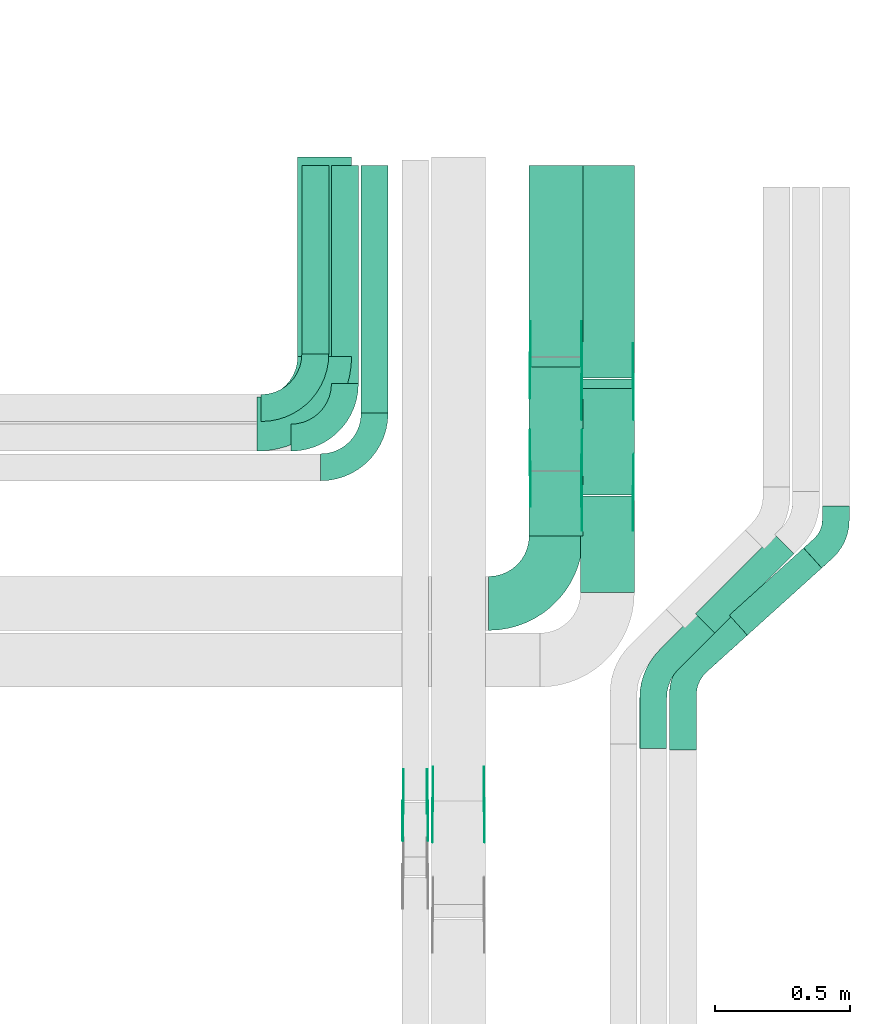
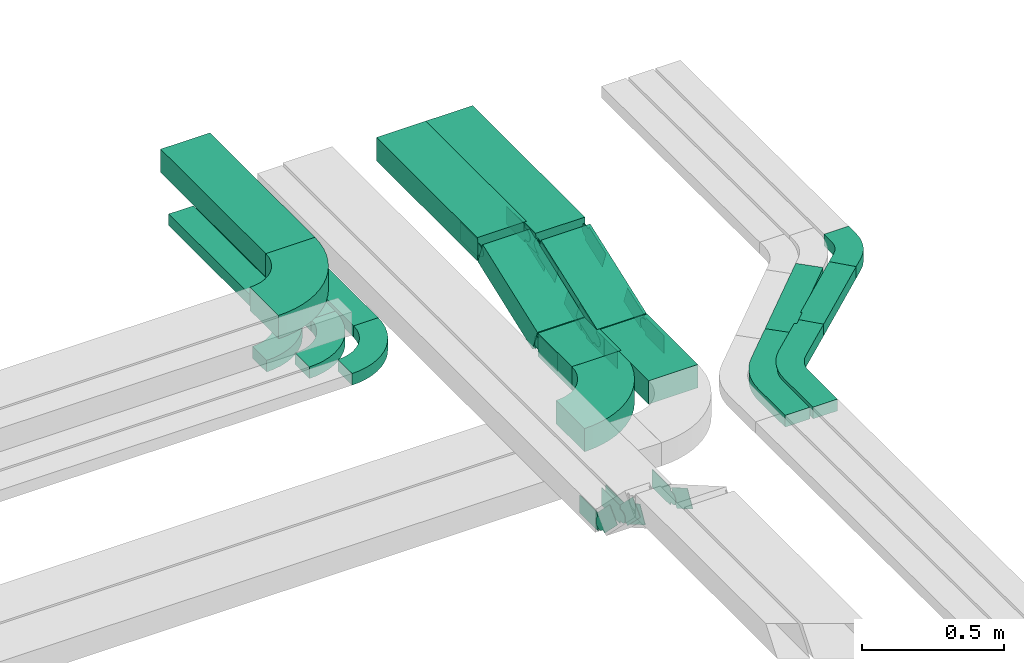
# One storey, part 22 of 25: 32 flow fittings, 12 flow segments.
"""IFC2X3 building model written with IfcOpenShell, lengths in millimetres."""

from ifc_helpers import new_model, entity, si_unit, converted_unit, derived_unit, direction, frame, frame_2d, origin, place, context, subcontext, project, spatial, polyline, circle_curve, parameter, trimmed, segment, composite_curve, rectangle, outline, extrude, source, transform, mapped, material, type_object, type_shapes, element, save


model = new_model("IFC2X3")

# Units and contexts
model_context = context("Model", 3, precision=0.01, world=origin(), true_north=direction((6.12303176911189e-17, 1.0)))
body_context = subcontext(model_context, "Body", "Model", "MODEL_VIEW")
ifc_project = project(units=[si_unit("LENGTHUNIT", "METRE", prefix="MILLI"), si_unit("AREAUNIT", "SQUARE_METRE"), si_unit("VOLUMEUNIT", "CUBIC_METRE"), converted_unit("PLANEANGLEUNIT", "DEGREE", entity("IfcRatioMeasure", 0.0174532925199433), si_unit("PLANEANGLEUNIT", "RADIAN"), dimensions=[0, 0, 0, 0, 0, 0, 0]), si_unit("MASSUNIT", "GRAM", prefix="KILO"), derived_unit("MASSDENSITYUNIT", [(si_unit("MASSUNIT", "GRAM", prefix="KILO"), 1), (si_unit("LENGTHUNIT", "METRE"), -3)]), derived_unit("MOMENTOFINERTIAUNIT", [(si_unit("LENGTHUNIT", "METRE"), 4)]), si_unit("TIMEUNIT", "SECOND"), si_unit("FREQUENCYUNIT", "HERTZ"), si_unit("THERMODYNAMICTEMPERATUREUNIT", "DEGREE_CELSIUS"), derived_unit("THERMALTRANSMITTANCEUNIT", [(si_unit("MASSUNIT", "GRAM", prefix="KILO"), 1), (si_unit("THERMODYNAMICTEMPERATUREUNIT", "KELVIN"), -1), (si_unit("TIMEUNIT", "SECOND"), -3)]), derived_unit("VOLUMETRICFLOWRATEUNIT", [(si_unit("LENGTHUNIT", "METRE"), 3), (si_unit("TIMEUNIT", "SECOND"), -1)]), derived_unit("MASSFLOWRATEUNIT", [(si_unit("MASSUNIT", "GRAM", prefix="KILO"), 1), (si_unit("TIMEUNIT", "SECOND"), -1)]), derived_unit("ROTATIONALFREQUENCYUNIT", [(si_unit("TIMEUNIT", "SECOND"), -1)]), si_unit("ELECTRICCURRENTUNIT", "AMPERE"), si_unit("ELECTRICVOLTAGEUNIT", "VOLT"), si_unit("POWERUNIT", "WATT"), si_unit("FORCEUNIT", "NEWTON", prefix="KILO"), si_unit("ILLUMINANCEUNIT", "LUX"), si_unit("LUMINOUSFLUXUNIT", "LUMEN"), si_unit("LUMINOUSINTENSITYUNIT", "CANDELA"), derived_unit("USERDEFINED", [(si_unit("MASSUNIT", "GRAM", prefix="KILO"), -1), (si_unit("LENGTHUNIT", "METRE"), -2), (si_unit("TIMEUNIT", "SECOND"), 3), (si_unit("LUMINOUSFLUXUNIT", "LUMEN"), 1)]), derived_unit("LINEARVELOCITYUNIT", [(si_unit("LENGTHUNIT", "METRE"), 1), (si_unit("TIMEUNIT", "SECOND"), -1)]), si_unit("PRESSUREUNIT", "PASCAL"), derived_unit("USERDEFINED", [(si_unit("LENGTHUNIT", "METRE"), -2), (si_unit("MASSUNIT", "GRAM", prefix="KILO"), 1), (si_unit("TIMEUNIT", "SECOND"), -2)]), derived_unit("LINEARFORCEUNIT", [(si_unit("MASSUNIT", "GRAM", prefix="KILO"), 1), (si_unit("LENGTHUNIT", "METRE"), 1), (si_unit("TIMEUNIT", "SECOND"), -2), (si_unit("LENGTHUNIT", "METRE"), -1)]), derived_unit("PLANARFORCEUNIT", [(si_unit("MASSUNIT", "GRAM", prefix="KILO"), 1), (si_unit("LENGTHUNIT", "METRE"), 1), (si_unit("TIMEUNIT", "SECOND"), -2), (si_unit("LENGTHUNIT", "METRE"), -2)])], contexts=[model_context])

# Site, building, storey
site_placement = place(None, frame((0.0, -0.00077364408347762, 0.0)))
site = spatial("IfcSite", under=ifc_project, at=site_placement, CompositionType="ELEMENT")
building_placement = place(site_placement, origin())
building = spatial("IfcBuilding", under=site, at=building_placement, CompositionType="ELEMENT")
storey_placement = place(building_placement, frame((0.0, 0.0, 24000.0)))
storey = spatial("IfcBuildingStorey", under=building, at=storey_placement, CompositionType="ELEMENT", Elevation=24000.0)

# Flow segments
cable_carrier_segment_type = type_object("IfcCableCarrierSegmentType", PredefinedType="CABLETRAYSEGMENT")
flow_segment_1_placement = place(storey_placement, frame((67285.5276000942, 9971.0, 2972.82677247422)))
element("IfcFlowSegment", 1, at=flow_segment_1_placement, inside=storey, type_object=cable_carrier_segment_type, context=body_context, shape_type="SweptSolid", body=[
    extrude(rectangle(XDim=699.000000000004, YDim=99.9999999999946, at=frame_2d((0.0, 4.33075797445781e-12), x_axis=(1.0, 0.0))), frame((50.0, 349.500000000003, 0.0), z_axis=(0.0, 0.0, 1.0), x_axis=(0.0, 1.0, 0.0)), (0.0, 0.0, 1.0), 49.9999999999973),
])
flow_segment_2_placement = place(storey_placement, frame((67395.5276000942, 9861.0, 2972.82677247422)))
element("IfcFlowSegment", 2, at=flow_segment_2_placement, inside=storey, type_object=cable_carrier_segment_type, context=body_context, shape_type="SweptSolid", body=[
    extrude(rectangle(XDim=809.000000000002, YDim=99.9999999999946, at=frame_2d((-1.08002495835535e-12, -4.33075797445781e-12), x_axis=(1.0, 0.0))), frame((50.0, 404.500000000003, 0.0), z_axis=(0.0, 0.0, 1.0), x_axis=(0.0, 1.0, 0.0)), (0.0, 0.0, 1.0), 49.9999999999973),
])
flow_segment_3_placement = place(storey_placement, frame((67505.5276000942, 9751.0, 2972.82677247422)))
element("IfcFlowSegment", 3, at=flow_segment_3_placement, inside=storey, type_object=cable_carrier_segment_type, context=body_context, shape_type="SweptSolid", body=[
    extrude(rectangle(XDim=919.000000000008, YDim=99.9999999999946, at=frame_2d((0.0, 4.33075797445781e-12), x_axis=(1.0, 0.0))), frame((50.0, 459.500000000004, 0.0), z_axis=(0.0, 0.0, 1.0), x_axis=(0.0, 1.0, 0.0)), (0.0, 0.0, 1.0), 49.9999999999973),
])
flow_segment_4_placement = place(storey_placement, frame((67270.0810452562, 9961.0, 3187.82677247422)))
element("IfcFlowSegment", 4, at=flow_segment_4_placement, inside=storey, type_object=cable_carrier_segment_type, context=body_context, shape_type="SweptSolid", body=[
    extrude(rectangle(XDim=739.518749019633, YDim=200.000000000007, at=frame_2d((-1.08002495835535e-12, 4.33431068813661e-12), x_axis=(1.0, 0.0))), frame((100.0, 369.759374509821, 0.0), z_axis=(0.0, 0.0, 1.0), x_axis=(0.0, 1.0, 0.0)), (0.0, 0.0, 1.0), 100.000000000003),
])
flow_segment_5_placement = place(storey_placement, frame((68871.1932036025, 8927.17520446877, 2977.04166610498)))
element("IfcFlowSegment", 5, at=flow_segment_5_placement, inside=storey, type_object=cable_carrier_segment_type, context=body_context, shape_type="SweptSolid", body=[
    extrude(rectangle(XDim=371.773074672143, YDim=99.9999999999984, at=frame_2d((2.8421709430404e-12, -3.31112914864207e-12), x_axis=(1.0, 0.0))), frame((171.457278030255, 161.706673583962, 0.283024091859215), z_axis=(0.00112985461369591, 0.00102060214396783, 0.999998840899236), x_axis=(-0.742072934551903, -0.67031741854538, 0.00152256368811346)), (0.0, 0.0, 1.0), 49.9999999999997),
])
flow_segment_6_placement = place(storey_placement, frame((68746.1523369545, 8935.60453032384, 2976.93564155154)))
element("IfcFlowSegment", 6, at=flow_segment_6_placement, inside=storey, type_object=cable_carrier_segment_type, context=body_context, shape_type="SweptSolid", body=[
    extrude(rectangle(XDim=415.989494553877, YDim=100.00000000001, at=frame_2d((-3.05533376376843e-12, 3.06599190480483e-12), x_axis=(1.0, 0.0))), frame((182.429503323364, 182.429503323343, 0.441935376893935), z_axis=(0.0015024201617621, 0.00150242016176191, 0.99999774273111), x_axis=(-0.707105185056458, -0.707105185056359, 0.00212474296914661)), (0.0, 0.0, 1.0), 50.0000000000083),
])
flow_segment_7_placement = place(storey_placement, frame((68128.7045667398, 9295.9892313259, 2805.0)))
element("IfcFlowSegment", 7, at=flow_segment_7_placement, inside=storey, type_object=cable_carrier_segment_type, context=body_context, shape_type="SweptSolid", body=[
    extrude(rectangle(XDim=238.258949212567, YDim=200.000000000007, at=frame_2d((0.0, 4.33431068813661e-12), x_axis=(1.0, 0.0))), frame((100.0, 119.129474606295, 0.0), z_axis=(0.0, 0.0, 1.0), x_axis=(0.0, 1.0, 0.0)), (0.0, 0.0, 1.0), 100.000000000003),
])
flow_segment_8_placement = place(storey_placement, frame((68319.2384978797, 9085.989231326, 2805.0)))
element("IfcFlowSegment", 8, at=flow_segment_8_placement, inside=storey, type_object=cable_carrier_segment_type, context=body_context, shape_type="SweptSolid", body=[
    extrude(rectangle(XDim=358.479361109274, YDim=200.000000000007, at=frame_2d((5.40012479177676e-13, 0.0), x_axis=(1.0, 0.0))), frame((100.0, 179.239680554637, 0.0), z_axis=(0.0, 0.0, 1.0), x_axis=(0.0, 1.0, 0.0)), (0.0, 0.0, 1.0), 100.000000000003),
])
flow_segment_9_placement = place(storey_placement, frame((68128.7045667398, 9960.74105078756, 2956.03437973935)))
element("IfcFlowSegment", 9, at=flow_segment_9_placement, inside=storey, type_object=cable_carrier_segment_type, context=body_context, shape_type="SweptSolid", body=[
    extrude(rectangle(XDim=709.258949212396, YDim=200.000000000007, at=frame_2d((1.08002495835535e-12, 4.33431068813661e-12), x_axis=(1.0, 0.0))), frame((100.0, 354.629474606204, 0.0), z_axis=(0.0, 0.0, 1.0), x_axis=(0.0, 1.0, 0.0)), (0.0, 0.0, 1.0), 100.000000000003),
])
flow_segment_10_placement = place(storey_placement, frame((68319.2384978797, 9880.52063889088, 2956.03437973935)))
element("IfcFlowSegment", 10, at=flow_segment_10_placement, inside=storey, type_object=cable_carrier_segment_type, context=body_context, shape_type="SweptSolid", body=[
    extrude(rectangle(XDim=789.479361109084, YDim=200.000000000007, at=frame_2d((1.08002495835535e-12, 0.0), x_axis=(1.0, 0.0))), frame((100.0, 394.739680554543, 0.0), z_axis=(0.0, 0.0, 1.0), x_axis=(0.0, 1.0, 0.0)), (0.0, 0.0, 1.0), 100.000000000003),
])
flow_segment_11_placement = place(storey_placement, frame((68128.7045667398, 9537.58278936662, 2811.90452506089)))
element("IfcFlowSegment", 11, at=flow_segment_11_placement, inside=storey, type_object=cable_carrier_segment_type, context=body_context, shape_type="SweptSolid", body=[
    extrude(rectangle(XDim=100.000000000003, YDim=410.773733093381, at=frame_2d((0.0, 0.0), x_axis=(0.0, 1.0))), frame((0.0, 209.911826296397, 118.612664808778), z_axis=(1.0, 0.0, 0.0), x_axis=(0.0, -0.936970044567182, -0.34940969589262)), (0.0, 0.0, 1.0), 200.000000000007),
])
flow_segment_12_placement = place(storey_placement, frame((68319.2384978797, 9447.77624067955, 2811.61265250806)))
element("IfcFlowSegment", 12, at=flow_segment_12_placement, inside=storey, type_object=cable_carrier_segment_type, context=body_context, shape_type="SweptSolid", body=[
    extrude(rectangle(XDim=100.000000000004, YDim=420.598079588431, at=frame_2d((-5.11590769747272e-13, 1.88293824976427e-13), x_axis=(0.0, 1.0))), frame((0.0, 214.718374983531, 118.904537361611), z_axis=(1.0, 0.0, 0.0), x_axis=(0.0, -0.939705127606637, -0.341985779163101)), (0.0, 0.0, 1.0), 200.000000000006),
])

# Flow fittings
ifc_material_1 = material(Name="G")
cable_carrier_fitting_type_1 = type_object("IfcCableCarrierFittingType", PredefinedType="NOTDEFINED", material=ifc_material_1)
shared_shape_1 = source(origin(), body_context, "Body", "SweptSolid", [
    extrude(outline(composite_curve([segment(trimmed(circle_curve(frame_2d((-41.4651162790697, 0.0), x_axis=(1.0, 0.0)), 25.0), [parameter(90.0000000000007)], [parameter(270.0)], True, "PARAMETER"), True, "CONTINUOUS"), segment(polyline([(-41.4651162790697, -25.0), (-29.9651162790697, -25.0)]), True, "CONTINUOUS"), segment(polyline([(-29.9651162790697, -25.0), (-28.1046511627907, -38.5)]), True, "CONTINUOUS"), segment(polyline([(-28.1046511627907, -38.5), (99.5348837209303, -38.5)]), True, "CONTINUOUS"), segment(polyline([(99.5348837209303, -38.5), (99.5348837209303, 38.5)]), True, "CONTINUOUS"), segment(polyline([(99.5348837209303, 38.5), (-28.1046511627907, 38.5)]), True, "CONTINUOUS"), segment(polyline([(-28.1046511627907, 38.5), (-29.9651162790697, 25.0)]), True, "CONTINUOUS"), segment(polyline([(-29.9651162790697, 25.0), (-41.46511627907, 25.0)]), True, "CONTINUOUS")], self_intersect=False)), frame((41.4651162790697, 0.0, 0.0), z_axis=(0.0, 0.0, -1.0), x_axis=(1.0, 0.0, 0.0)), (0.0, 0.0, -1.0), 2.0),
])
type_shapes(cable_carrier_fitting_type_1, [shared_shape_1])
for number, where, z_axis, x_axis in (
    (13, (68324.16456675, 9950.0, 3006.03437973937), (1.0, 0.0, 0.0), (0.0, -0.93697004456712, -0.349409695892785)),
    (14, (68324.16456675, 9544.98923132608, 2855.0), (1.0, 0.0, 0.0), (0.0, 0.93697004456712, 0.349409695892785)),
    (15, (68514.6984978899, 9870.0, 3006.03437973937), (1.0, 0.0, 0.0), (0.0, -0.939705127606558, -0.34198577916332)),
    (16, (68514.6984978899, 9454.9892313262, 2855.0), (1.0, 0.0, 0.0), (0.0, 0.939705127606558, 0.34198577916332)),
    (17, (67770.8875285364, 8298.27683305022, 3005.26809891813), (-1.0, 0.0, 0.0), (0.0, -0.866025403784327, 0.500000000000193)),
    (18, (67660.8875285364, 8288.93441568023, 3005.26809891815), (-1.0, 0.0, 0.0), (0.0, -0.707106781186429, 0.707106781186666)),
):
    element("IfcFlowFitting", number, at=place(storey_placement, frame(where, z_axis=z_axis, x_axis=x_axis)), inside=storey, type_object=cable_carrier_fitting_type_1, material=ifc_material_1, context=body_context, shape_type="MappedRepresentation", body=[
        mapped(shared_shape_1, transform((0.0, 0.0, 0.0), scale=1.0)),
    ])
cable_carrier_fitting_type_2 = type_object("IfcCableCarrierFittingType", PredefinedType="NOTDEFINED", material=ifc_material_1)
shared_shape_2 = source(origin(), body_context, "Body", "SweptSolid", [
    extrude(outline(composite_curve([segment(trimmed(circle_curve(frame_2d((-41.4651162790697, 0.0), x_axis=(1.0, 0.0)), 25.0), [parameter(90.0000000000007)], [parameter(270.0)], True, "PARAMETER"), True, "CONTINUOUS"), segment(polyline([(-41.4651162790697, -25.0), (-29.9651162790697, -25.0)]), True, "CONTINUOUS"), segment(polyline([(-29.9651162790697, -25.0), (-28.1046511627907, -38.5)]), True, "CONTINUOUS"), segment(polyline([(-28.1046511627907, -38.5), (99.5348837209303, -38.5)]), True, "CONTINUOUS"), segment(polyline([(99.5348837209303, -38.5), (99.5348837209303, 38.5)]), True, "CONTINUOUS"), segment(polyline([(99.5348837209303, 38.5), (-28.1046511627907, 38.5)]), True, "CONTINUOUS"), segment(polyline([(-28.1046511627907, 38.5), (-29.9651162790697, 25.0)]), True, "CONTINUOUS"), segment(polyline([(-29.9651162790697, 25.0), (-41.46511627907, 25.0)]), True, "CONTINUOUS")], self_intersect=False)), frame((41.4651162790697, 0.0, 0.0)), (0.0, 0.0, 1.0), 2.0),
])
type_shapes(cable_carrier_fitting_type_2, [shared_shape_2])
for number, where, z_axis, x_axis in (
    (19, (68133.2445667297, 9950.0, 3006.03437973937), (-1.0, 0.0, 0.0), (0.0, -0.93697004456712, -0.349409695892785)),
    (20, (68133.2445667297, 9544.98923132608, 2855.0), (-1.0, 0.0, 0.0), (0.0, 0.93697004456712, 0.349409695892785)),
    (21, (68323.7784978696, 9870.0, 3006.03437973937), (-1.0, 0.0, 0.0), (0.0, -0.939705127606558, -0.34198577916332)),
    (22, (68323.7784978696, 9454.98923132619, 2855.0), (-1.0, 0.0, 0.0), (0.0, 0.939705127606558, 0.34198577916332)),
    (23, (67961.8075285568, 8298.27683305022, 3005.26809891813), (1.0, 0.0, 0.0), (0.0, -0.866025403784327, 0.500000000000193)),
    (24, (67751.8075285568, 8288.93441568023, 3005.26809891815), (1.0, 0.0, 0.0), (0.0, -0.707106781186429, 0.707106781186666)),
):
    element("IfcFlowFitting", number, at=place(storey_placement, frame(where, z_axis=z_axis, x_axis=x_axis)), inside=storey, type_object=cable_carrier_fitting_type_2, material=ifc_material_1, context=body_context, shape_type="MappedRepresentation", body=[
        mapped(shared_shape_2, transform((0.0, 0.0, 0.0), scale=1.0)),
    ])
cable_carrier_fitting_type_3 = type_object("IfcCableCarrierFittingType", PredefinedType="NOTDEFINED", material=ifc_material_1)
shared_shape_3 = source(origin(), body_context, "Body", "SweptSolid", [
    extrude(outline(composite_curve([segment(trimmed(circle_curve(frame_2d((-41.4651162790697, 0.0), x_axis=(1.0, 0.0)), 25.0), [parameter(90.0000000000007)], [parameter(270.0)], True, "PARAMETER"), True, "CONTINUOUS"), segment(polyline([(-41.4651162790697, -25.0), (-29.9651162790697, -25.0)]), True, "CONTINUOUS"), segment(polyline([(-29.9651162790697, -25.0), (-28.1046511627907, -38.5)]), True, "CONTINUOUS"), segment(polyline([(-28.1046511627907, -38.5), (99.5348837209303, -38.5)]), True, "CONTINUOUS"), segment(polyline([(99.5348837209303, -38.5), (99.5348837209303, 38.5)]), True, "CONTINUOUS"), segment(polyline([(99.5348837209303, 38.5), (-28.1046511627907, 38.5)]), True, "CONTINUOUS"), segment(polyline([(-28.1046511627907, 38.5), (-29.9651162790697, 25.0)]), True, "CONTINUOUS"), segment(polyline([(-29.9651162790697, 25.0), (-41.46511627907, 25.0)]), True, "CONTINUOUS")], self_intersect=False)), frame((41.4651162790697, 0.0, 0.0), z_axis=(0.0, 0.0, -1.0), x_axis=(1.0, 0.0, 0.0)), (0.0, 0.0, -1.0), 2.0),
])
type_shapes(cable_carrier_fitting_type_3, [shared_shape_3])
for number, where, z_axis, x_axis in (
    (25, (68135.2445667297, 9950.0, 3006.03437973937), (-1.0, 0.0, 0.0), (0.0, 1.0, 0.0)),
    (26, (68135.2445667297, 9544.98923132609, 2855.0), (-1.0, 0.0, 0.0), (0.0, -1.0, 0.0)),
    (27, (68325.7784978696, 9870.0, 3006.03437973937), (-1.0, 0.0, 0.0), (0.0, 1.0, 0.0)),
    (28, (68325.7784978696, 9454.98923132621, 2855.0), (-1.0, 0.0, 0.0), (0.0, -1.0, 0.0)),
    (29, (67959.8075285568, 8298.27683305021, 3005.26809891814), (1.0, 0.0, 0.0), (0.0, 1.0, 0.0)),
    (30, (67749.8075285568, 8288.93441568023, 3005.26809891815), (1.0, 0.0, 0.0), (0.0, 1.0, 0.0)),
):
    element("IfcFlowFitting", number, at=place(storey_placement, frame(where, z_axis=z_axis, x_axis=x_axis)), inside=storey, type_object=cable_carrier_fitting_type_3, material=ifc_material_1, context=body_context, shape_type="MappedRepresentation", body=[
        mapped(shared_shape_3, transform((0.0, 0.0, 0.0), scale=1.0)),
    ])
cable_carrier_fitting_type_4 = type_object("IfcCableCarrierFittingType", PredefinedType="NOTDEFINED", material=ifc_material_1)
shared_shape_4 = source(origin(), body_context, "Body", "SweptSolid", [
    extrude(outline(composite_curve([segment(trimmed(circle_curve(frame_2d((-41.4651162790697, 0.0), x_axis=(1.0, 0.0)), 25.0), [parameter(90.0000000000007)], [parameter(270.0)], True, "PARAMETER"), True, "CONTINUOUS"), segment(polyline([(-41.4651162790697, -25.0), (-29.9651162790697, -25.0)]), True, "CONTINUOUS"), segment(polyline([(-29.9651162790697, -25.0), (-28.1046511627907, -38.5)]), True, "CONTINUOUS"), segment(polyline([(-28.1046511627907, -38.5), (99.5348837209303, -38.5)]), True, "CONTINUOUS"), segment(polyline([(99.5348837209303, -38.5), (99.5348837209303, 38.5)]), True, "CONTINUOUS"), segment(polyline([(99.5348837209303, 38.5), (-28.1046511627907, 38.5)]), True, "CONTINUOUS"), segment(polyline([(-28.1046511627907, 38.5), (-29.9651162790697, 25.0)]), True, "CONTINUOUS"), segment(polyline([(-29.9651162790697, 25.0), (-41.46511627907, 25.0)]), True, "CONTINUOUS")], self_intersect=False)), frame((41.4651162790697, 0.0, 0.0)), (0.0, 0.0, 1.0), 2.0),
])
type_shapes(cable_carrier_fitting_type_4, [shared_shape_4])
for number, where, z_axis, x_axis in (
    (31, (68322.16456675, 9950.0, 3006.03437973937), (1.0, 0.0, 0.0), (0.0, 1.0, 0.0)),
    (32, (68322.16456675, 9544.98923132609, 2855.0), (1.0, 0.0, 0.0), (0.0, -1.0, 0.0)),
    (33, (68512.6984978899, 9870.0, 3006.03437973937), (1.0, 0.0, 0.0), (0.0, 1.0, 0.0)),
    (34, (68512.6984978899, 9454.98923132621, 2855.0), (1.0, 0.0, 0.0), (0.0, -1.0, 0.0)),
    (35, (67772.8875285364, 8298.27683305021, 3005.26809891814), (-1.0, 0.0, 0.0), (0.0, 1.0, 0.0)),
    (36, (67662.8875285364, 8288.93441568023, 3005.26809891816), (-1.0, 0.0, 0.0), (0.0, 1.0, 0.0)),
):
    element("IfcFlowFitting", number, at=place(storey_placement, frame(where, z_axis=z_axis, x_axis=x_axis)), inside=storey, type_object=cable_carrier_fitting_type_4, material=ifc_material_1, context=body_context, shape_type="MappedRepresentation", body=[
        mapped(shared_shape_4, transform((0.0, 0.0, 0.0), scale=1.0)),
    ])
ifc_material_2 = material()
cable_carrier_fitting_type_5 = type_object("IfcCableCarrierFittingType", Name="470_DKC_S5_Variable Angle Elbow 0-45:-", PredefinedType="NOTDEFINED", material=ifc_material_2)
shared_shape_5 = source(origin(), body_context, "Body", "SweptSolid", [
    extrude(outline(composite_curve([segment(polyline([(-125.750000000001, -225.25), (-124.749999999999, -225.25)]), True, "CONTINUOUS"), segment(trimmed(circle_curve(frame_2d((-124.75, 124.75), x_axis=(0.0, -1.0)), 350.0), [parameter(0.0)], [parameter(90.0000000000001)], True, "PARAMETER"), True, "CONTINUOUS"), segment(polyline([(225.25, 124.75), (225.25, 125.749999999999)]), True, "CONTINUOUS"), segment(polyline([(225.25, 125.749999999999), (25.25, 125.750000000001)]), True, "CONTINUOUS"), segment(polyline([(25.25, 125.750000000001), (25.25, 124.75)]), True, "CONTINUOUS"), segment(trimmed(circle_curve(frame_2d((-124.75, 124.75), x_axis=(0.0, -1.0)), 150.0), [parameter(0.0)], [parameter(90.0000000000001)], True, "PARAMETER"), False, "CONTINUOUS"), segment(polyline([(-124.749999999999, -25.2500000000003), (-125.750000000001, -25.2500000000003)]), True, "CONTINUOUS"), segment(polyline([(-125.750000000001, -25.2500000000003), (-125.750000000001, -225.25)]), True, "CONTINUOUS")], self_intersect=False)), frame((-125.249999999991, 125.249999999992, -50.0)), (0.0, 0.0, 1.0), 100.0),
])
type_shapes(cable_carrier_fitting_type_5, [shared_shape_5])
for number, where, name in (
    (37, (67370.0810452562, 9710.0, 3237.82677247422), "470_DKC_S5_Variable Angle Elbow 0-45:-"),
    (38, (68228.7045667398, 9044.98923132593, 2855.0), "470_DKC_S5_Variable Angle Elbow 0-45:-"),
):
    element("IfcFlowFitting", number, at=place(storey_placement, frame(where)), inside=storey, type_object=cable_carrier_fitting_type_5, material=ifc_material_2, Name=name, ObjectType="470_DKC_S5_Variable Angle Elbow 0-45:-", context=body_context, shape_type="MappedRepresentation", body=[
        mapped(shared_shape_5, transform((0.0, 0.0, 0.0), scale=1.0)),
    ])
cable_carrier_fitting_type_6 = type_object("IfcCableCarrierFittingType", Name="470_DKC_S5_Variable Angle Elbow 0-45:-", PredefinedType="NOTDEFINED", material=ifc_material_2)
shared_shape_6 = source(origin(), body_context, "Body", "SweptSolid", [
    extrude(outline(composite_curve([segment(polyline([(-100.750000000001, -150.25), (-99.7499999999994, -150.25)]), True, "CONTINUOUS"), segment(trimmed(circle_curve(frame_2d((-99.7499999999997, 99.7499999999995), x_axis=(0.0, -1.0)), 250.0), [parameter(0.0)], [parameter(90.0000000000001)], True, "PARAMETER"), True, "CONTINUOUS"), segment(polyline([(150.25, 99.75), (150.25, 100.749999999999)]), True, "CONTINUOUS"), segment(polyline([(150.25, 100.749999999999), (50.25, 100.75)]), True, "CONTINUOUS"), segment(polyline([(50.25, 100.75), (50.25, 99.7499999999998)]), True, "CONTINUOUS"), segment(trimmed(circle_curve(frame_2d((-99.7499999999997, 99.7499999999995), x_axis=(0.0, -1.0)), 150.0), [parameter(0.0)], [parameter(90.0000000000001)], True, "PARAMETER"), False, "CONTINUOUS"), segment(polyline([(-99.7499999999994, -50.2500000000003), (-100.750000000001, -50.2500000000003)]), True, "CONTINUOUS"), segment(polyline([(-100.750000000001, -50.2500000000003), (-100.750000000001, -150.25)]), True, "CONTINUOUS")], self_intersect=False)), frame((-100.249999999991, 100.249999999992, -25.0)), (0.0, 0.0, 1.0), 49.9999999999997),
])
type_shapes(cable_carrier_fitting_type_6, [shared_shape_6])
for number, where, name in (
    (39, (67335.5276000942, 9770.0, 2997.82677247422), "470_DKC_S5_Variable Angle Elbow 0-45:-"),
    (40, (67445.5276000942, 9660.0, 2997.82677247422), "470_DKC_S5_Variable Angle Elbow 0-45:-"),
    (41, (67555.5276000942, 9550.0, 2997.82677247422), "470_DKC_S5_Variable Angle Elbow 0-45:-"),
):
    element("IfcFlowFitting", number, at=place(storey_placement, frame(where)), inside=storey, type_object=cable_carrier_fitting_type_6, material=ifc_material_2, Name=name, ObjectType="470_DKC_S5_Variable Angle Elbow 0-45:-", context=body_context, shape_type="MappedRepresentation", body=[
        mapped(shared_shape_6, transform((0.0, 0.0, 0.0), scale=1.0)),
    ])
cable_carrier_fitting_type_7 = type_object("IfcCableCarrierFittingType", Name="470_DKC_S5_CD 90 external vertical angle:-", PredefinedType="NOTDEFINED", material=ifc_material_2)
shared_shape_7 = source(origin(), body_context, "Body", "SweptSolid", [
    extrude(outline(composite_curve([segment(polyline([(-100.840217544273, -82.9627933027741), (-47.5527344484616, -82.9627933027741)]), True, "CONTINUOUS"), segment(trimmed(circle_curve(frame_2d((-47.5527344484617, 107.037206697225), x_axis=(0.0, -1.0)), 189.999999999999), [parameter(0.0)], [parameter(47.9076715108795)], True, "PARAMETER"), True, "CONTINUOUS"), segment(polyline([(93.4397295208654, -20.3249741252532), (129.159782455726, 19.2178339821276)]), True, "CONTINUOUS"), segment(polyline([(129.159782455726, 19.2178339821276), (54.9532224718693, 86.250560730801)]), True, "CONTINUOUS"), segment(polyline([(54.9532224718692, 86.250560730801), (19.2331695370084, 46.70775262342)]), True, "CONTINUOUS"), segment(trimmed(circle_curve(frame_2d((-47.5527344484617, 107.037206697225), x_axis=(0.0, -1.0)), 89.9999999999988), [parameter(0.0)], [parameter(47.9076715108795)], True, "PARAMETER"), False, "CONTINUOUS"), segment(polyline([(-47.5527344484615, 17.0372066972262), (-100.840217544273, 17.0372066972262)]), True, "CONTINUOUS"), segment(polyline([(-100.840217544273, 17.0372066972262), (-100.840217544273, -82.9627933027741)]), True, "CONTINUOUS")], self_intersect=False)), frame((-14.6441691162524, 32.9627933027667, -25.0)), (0.0, 0.0, 1.0), 49.9999999999999),
])
type_shapes(cable_carrier_fitting_type_7, [shared_shape_7])
flow_fitting_1_placement = place(storey_placement, frame((69266.3165005179, 9290.92027807334, 3001.35093650816), z_axis=(0.00369935697622955, 0.00482711190193455, 0.999981506703323), x_axis=(0.742060522147523, 0.670306206371416, -0.00598090044267332)))
element("IfcFlowFitting", 42, at=flow_fitting_1_placement, inside=storey, type_object=cable_carrier_fitting_type_7, material=ifc_material_2, Name="470_DKC_S5_CD 90 external vertical angle:-", ObjectType="470_DKC_S5_CD 90 external vertical angle:-", context=body_context, shape_type="MappedRepresentation", body=[
    mapped(shared_shape_7, transform((0.0, 0.0, 0.0), scale=1.0)),
])
cable_carrier_fitting_type_8 = type_object("IfcCableCarrierFittingType", Name="470_DKC_S5_CS 90 internal vertical angle:-", PredefinedType="NOTDEFINED", material=ifc_material_2)
shared_shape_8 = source(origin(), body_context, "Body", "SweptSolid", [
    extrude(outline(composite_curve([segment(polyline([(-248.247317269892, -115.011040671116), (-44.4214547208251, -115.011040671116)]), True, "CONTINUOUS"), segment(trimmed(circle_curve(frame_2d((-44.4214547208254, 99.9889593288827), x_axis=(0.0, -1.0)), 214.999999999999), [parameter(0.0)], [parameter(47.9076715108795)], True, "PARAMETER"), True, "CONTINUOUS"), segment(polyline([(115.122649244466, -44.1314031807637), (251.752682730108, 107.120757774322)]), True, "CONTINUOUS"), segment(polyline([(251.752682730108, 107.120757774322), (177.546122746251, 174.153484522996)]), True, "CONTINUOUS"), segment(polyline([(177.546122746251, 174.153484522996), (40.916089260609, 22.9013235679095)]), True, "CONTINUOUS"), segment(trimmed(circle_curve(frame_2d((-44.4214547208254, 99.9889593288827), x_axis=(0.0, -1.0)), 114.999999999999), [parameter(0.0)], [parameter(47.9076715108795)], True, "PARAMETER"), False, "CONTINUOUS"), segment(polyline([(-44.4214547208251, -15.011040671116), (-248.247317269892, -15.011040671116)]), True, "CONTINUOUS"), segment(polyline([(-248.247317269892, -15.011040671116), (-248.247317269892, -115.011040671116)]), True, "CONTINUOUS")], self_intersect=False)), frame((-28.8820387661607, 65.0110406711088, -25.0)), (0.0, 0.0, 1.0), 49.9999999999999),
])
type_shapes(cable_carrier_fitting_type_8, [shared_shape_8])
flow_fitting_2_placement = place(storey_placement, frame((68699.0906051009, 8778.5428819382, 3004.26516839937), z_axis=(0.0036993569762315, 0.00482711190194246, 0.999981506703323), x_axis=(-0.742060522147543, -0.670306206371395, 0.00598090044268004)))
element("IfcFlowFitting", 43, at=flow_fitting_2_placement, inside=storey, type_object=cable_carrier_fitting_type_8, material=ifc_material_2, Name="470_DKC_S5_CS 90 internal vertical angle:-", ObjectType="470_DKC_S5_CS 90 internal vertical angle:-", context=body_context, shape_type="MappedRepresentation", body=[
    mapped(shared_shape_8, transform((0.0, 0.0, 0.0), scale=1.0)),
])
cable_carrier_fitting_type_9 = type_object("IfcCableCarrierFittingType", Name="470_DKC_S5_CS 90 internal vertical angle:-", PredefinedType="NOTDEFINED", material=ifc_material_2)
shared_shape_9 = source(origin(), body_context, "Body", "SweptSolid", [
    extrude(outline(composite_curve([segment(polyline([(-246.186418404585, -112.760191002141), (-56.8465901844057, -112.760191002141)]), True, "CONTINUOUS"), segment(trimmed(circle_curve(frame_2d((-56.8465901844061, 137.239808997858), x_axis=(0.0, -1.0)), 249.999999999999), [parameter(0.0)], [parameter(45.0)], True, "PARAMETER"), True, "CONTINUOUS"), segment(polyline([(119.93010511223, -39.5368862987784), (253.813581595415, 94.3465901844058)]), True, "CONTINUOUS"), segment(polyline([(253.813581595415, 94.3465901844057), (183.10290347676, 165.057268303061)]), True, "CONTINUOUS"), segment(polyline([(183.10290347676, 165.057268303061), (49.2194269935753, 31.1737918198764)]), True, "CONTINUOUS"), segment(trimmed(circle_curve(frame_2d((-56.8465901844061, 137.239808997858), x_axis=(0.0, -1.0)), 149.999999999999), [parameter(0.0)], [parameter(45.0)], True, "PARAMETER"), False, "CONTINUOUS"), segment(polyline([(-56.8465901844057, -12.7601910021412), (-246.186418404585, -12.7601910021412)]), True, "CONTINUOUS"), segment(polyline([(-246.186418404585, -12.7601910021412), (-246.186418404585, -112.760191002141)]), True, "CONTINUOUS")], self_intersect=False)), frame((-25.9961222902041, 62.760191002134, -25.0)), (0.0, 0.0, 1.0), 49.9999999999999),
])
type_shapes(cable_carrier_fitting_type_9, [shared_shape_9])
flow_fitting_3_placement = place(storey_placement, frame((68589.0867517315, 8778.5389451008, 3004.49239535428), z_axis=(0.0037457883770944, 0.00494651364861597, 0.999980750350805), x_axis=(-0.70709342449057, -0.707093424490507, 0.00614638792187687)))
element("IfcFlowFitting", 44, at=flow_fitting_3_placement, inside=storey, type_object=cable_carrier_fitting_type_9, material=ifc_material_2, Name="470_DKC_S5_CS 90 internal vertical angle:-", ObjectType="470_DKC_S5_CS 90 internal vertical angle:-", context=body_context, shape_type="MappedRepresentation", body=[
    mapped(shared_shape_9, transform((0.0, 0.0, 0.0), scale=1.0)),
])

save(model, "model.ifc")
